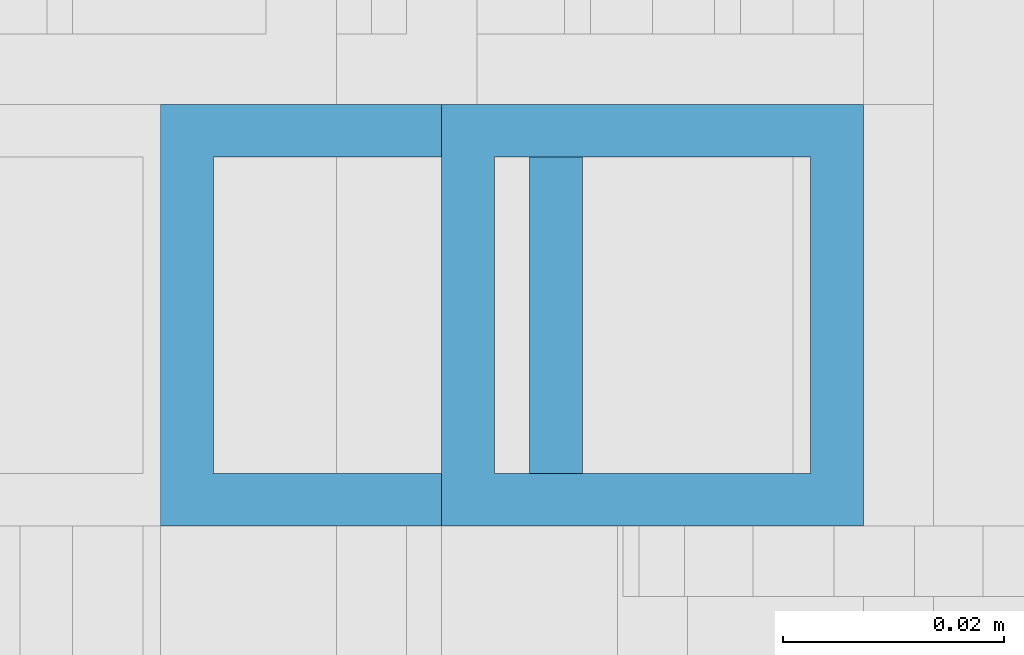
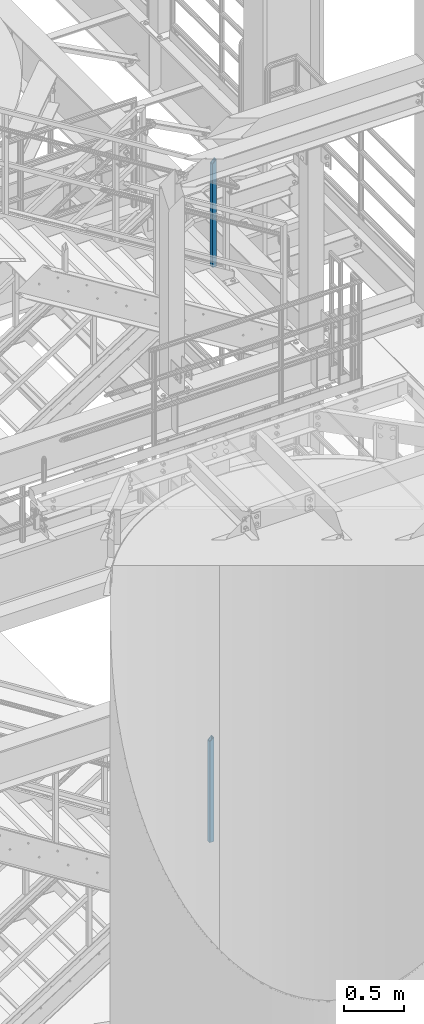
# One storey, part 642 of 1876: 2 columns, 2 elements without a shape of their own.
"""IFC2X3 building model written with IfcOpenShell, lengths in millimetres."""

from ifc_helpers import new_model, si_unit, frame, origin_with_axes, place, context, subcontext, project, spatial, faceted_brep, material, type_object, element, aggregate, save


model = new_model("IFC2X3")

# Units and contexts
model_context = context("Model", 3, precision=1e-05, world=origin_with_axes())
body_context = subcontext(model_context, "Body", "Model", "MODEL_VIEW")
ifc_project = project(units=[si_unit("LENGTHUNIT", "METRE", prefix="MILLI"), si_unit("AREAUNIT", "SQUARE_METRE"), si_unit("VOLUMEUNIT", "CUBIC_METRE"), si_unit("MASSUNIT", "GRAM", prefix="KILO"), si_unit("TIMEUNIT", "SECOND"), si_unit("PLANEANGLEUNIT", "RADIAN"), si_unit("SOLIDANGLEUNIT", "STERADIAN"), si_unit("THERMODYNAMICTEMPERATUREUNIT", "DEGREE_CELSIUS"), si_unit("LUMINOUSINTENSITYUNIT", "LUMEN")], contexts=[model_context])

# Site, building, storey
site_placement = place(None, origin_with_axes())
site = spatial("IfcSite", under=ifc_project, at=site_placement, CompositionType="ELEMENT")
building_placement = place(site_placement, origin_with_axes())
building = spatial("IfcBuilding", under=site, at=building_placement, Name="Undefined", CompositionType="ELEMENT")
storey_placement = place(building_placement, origin_with_axes())
storey = spatial("IfcBuildingStorey", under=building, at=storey_placement, Name="Undefined", CompositionType="ELEMENT", Elevation=0.0)

# Assembly, column
assembly_1_placement = place(storey_placement, origin_with_axes())
assembly_1 = element("IfcElementAssembly", 1, at=assembly_1_placement, inside=storey, Name="RAIL", AssemblyPlace="NOTDEFINED", PredefinedType="RIGID_FRAME")
ifc_material = material()
column_type = type_object("IfcColumnType", Name="HSS1-1/2X1-1/2X3/16", PredefinedType="NOTDEFINED")
column_1_placement = place(assembly_1_placement, frame((6248.400000012, -5734.05000114554, 2329.68362061127), z_axis=(-1.0, 0.0, 0.0), x_axis=(0.0, 0.0, 1.0)))
column_1 = element("IfcColumn", 2, at=column_1_placement, type_object=column_type, material=ifc_material, Name="POST", ObjectType="HSS1-1/2X1-1/2X3/16", context=body_context, shape_type="Brep", body=[
    faceted_brep([(0.0, 14.2874994260001, -14.2874994260001), (0.0, -14.2874994260001, -14.2874994260001), (1055.687499426, -14.2874994260001, -14.2874994260001), (1055.687499426, 14.2874994260001, -14.2874994260001), (0.0, -14.2874994260001, 14.2874994260001), (1027.112500574, -14.2874994260001, 14.2874994260001), (0.0, 14.2874994260001, 14.2874994260001), (1027.112500574, 14.2874994260001, 14.2874994260001), (0.0, 19.0499992349996, -19.0499992350001), (0.0, 19.0499992349996, 19.0499992349996), (1022.350000765, 19.0499992349996, 19.0499992349996), (1060.449999235, 19.0499992349996, -19.0499992349996), (0.0, -19.0499992349996, 19.0499992349996), (1022.350000765, -19.0499992349996, 19.0499992349996), (0.0, -19.0499992349996, -19.0499992350001), (1060.449999235, -19.0499992349996, -19.0499992349996)], [[[0, 1, 2, 3]], [[1, 4, 5, 2]], [[4, 6, 7, 5]], [[6, 0, 3, 7]], [[8, 9, 10, 11]], [[9, 12, 13, 10]], [[12, 14, 15, 13]], [[14, 8, 11, 15]], [[13, 15, 11, 10], [5, 7, 3, 2]], [[14, 12, 9, 8], [6, 4, 1, 0]]]),
])
aggregate(assembly_1, [column_1])

assembly_2_placement = place(storey_placement, origin_with_axes())
assembly_2 = element("IfcElementAssembly", 3, at=assembly_2_placement, inside=storey, Name="RAIL", AssemblyPlace="NOTDEFINED", PredefinedType="RIGID_FRAME")
column_2_placement = place(assembly_2_placement, frame((6273.79999407756, -5734.05000114554, 8153.40000000107), z_axis=(-1.0, 0.0, 0.0), x_axis=(0.0, 0.0, 1.0)))
column_2 = element("IfcColumn", 4, at=column_2_placement, type_object=column_type, material=ifc_material, Name="POST", ObjectType="HSS1-1/2X1-1/2X3/16", context=body_context, shape_type="Brep", body=[
    faceted_brep([(0.0, 14.2874994260001, -14.2874994260001), (0.0, -14.2874994260001, -14.2874994260001), (1081.08750016379, -14.2874994260001, -14.2874994260001), (1081.08750230446, 14.2874994260001, -14.2874994260001), (0.0, -14.2874994260001, 14.2874994260001), (1052.51250130933, -14.2874994260001, 14.2874994260001), (0.0, 14.2874994260001, 14.2874994260001), (1052.51250345492, 14.2874994260001, 14.2874994260001), (0.0, 19.0499992349996, -19.0499992350001), (0.0, 19.0499992349996, 19.0499992349996), (1047.7500040031, 19.0499992349996, 19.0499992349996), (1085.85000247064, 19.0499992349996, -19.0499992349996), (0.0, -19.0499992349996, 19.0499992349996), (1047.75000114315, -19.0499992349996, 19.0499992349996), (0.0, -19.0499992349996, -19.0499992350001), (1085.8499996156, -19.0499992349996, -19.0499992349996)], [[[0, 1, 2, 3]], [[1, 4, 5, 2]], [[4, 6, 7, 5]], [[6, 0, 3, 7]], [[8, 9, 10, 11]], [[9, 12, 13, 10]], [[12, 14, 15, 13]], [[14, 8, 11, 15]], [[13, 15, 11, 10], [5, 7, 3, 2]], [[14, 12, 9, 8], [6, 4, 1, 0]]]),
])
aggregate(assembly_2, [column_2])

save(model, "model.ifc")
